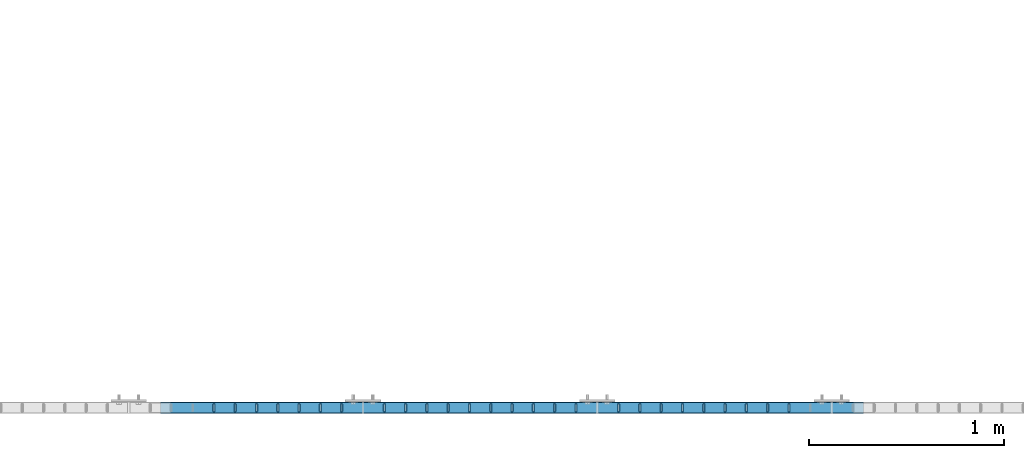
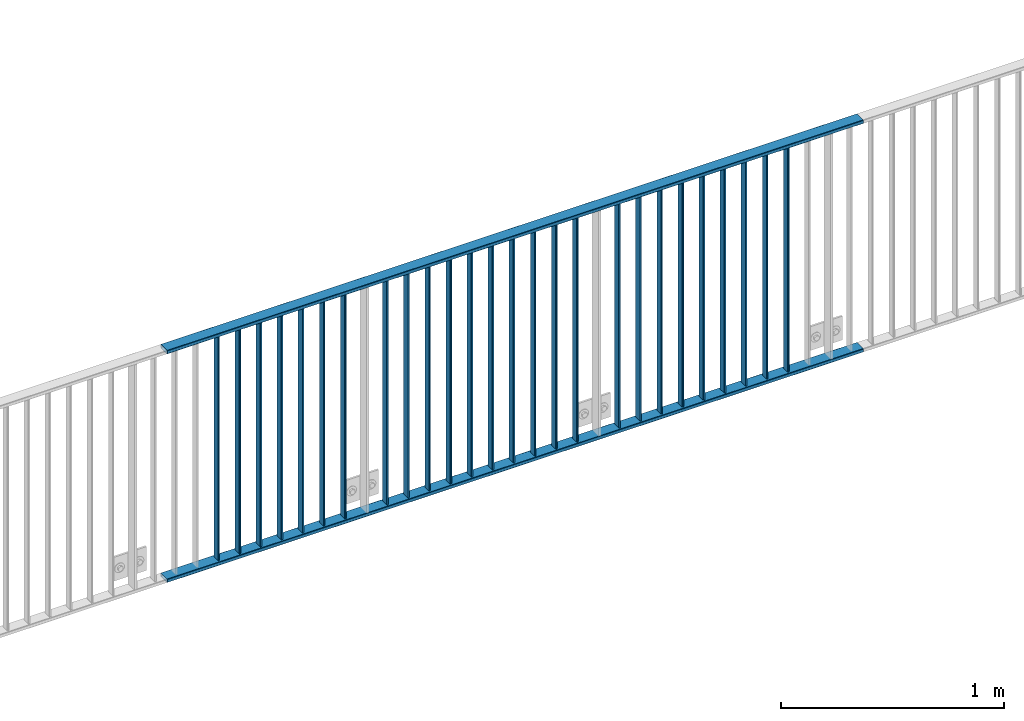
# One storey, part 21 of 156: 28 beams, 1 element without a shape of its own.
"""IFC2X3 building model written with IfcOpenShell, lengths in millimetres."""

from ifc_helpers import new_model, si_unit, frame, origin_with_axes, origin_2d_with_axis, place, context, subcontext, project, spatial, hollow_rectangle, extrude, clip, halfspace, material, type_object, element, aggregate, save


model = new_model("IFC2X3")

# Units and contexts
model_context = context("Model", 3, precision=1e-05, world=origin_with_axes())
body_context = subcontext(model_context, "Body", "Model", "MODEL_VIEW")
ifc_project = project(units=[si_unit("LENGTHUNIT", "METRE", prefix="MILLI"), si_unit("AREAUNIT", "SQUARE_METRE"), si_unit("VOLUMEUNIT", "CUBIC_METRE"), si_unit("MASSUNIT", "GRAM", prefix="KILO"), si_unit("TIMEUNIT", "SECOND"), si_unit("PLANEANGLEUNIT", "RADIAN"), si_unit("SOLIDANGLEUNIT", "STERADIAN"), si_unit("THERMODYNAMICTEMPERATUREUNIT", "DEGREE_CELSIUS"), si_unit("LUMINOUSINTENSITYUNIT", "LUMEN")], contexts=[model_context])

# Site, building, storey
site_placement = place(None, origin_with_axes())
site = spatial("IfcSite", under=ifc_project, at=site_placement, CompositionType="ELEMENT")
building_placement = place(site_placement, origin_with_axes())
building = spatial("IfcBuilding", under=site, at=building_placement, Name="Undefined", CompositionType="ELEMENT")
storey_placement = place(building_placement, origin_with_axes())
storey = spatial("IfcBuildingStorey", under=building, at=storey_placement, Name="Undefined", CompositionType="ELEMENT", Elevation=0.0)

# Assembly, beams
assembly_placement = place(storey_placement, origin_with_axes())
assembly = element("IfcElementAssembly", 1, at=assembly_placement, inside=storey, AssemblyPlace="NOTDEFINED", PredefinedType="RIGID_FRAME")
ifc_material = material(Name="STEEL/S235JR")
beam_type_1 = type_object("IfcBeamType", Name="K60/20/2", PredefinedType="NOTDEFINED")
beam_1_placement = place(assembly_placement, frame((35963.0399999997, 8480.00209045411, 2740.0), z_axis=(0.0, 1.0, 0.0), x_axis=(1.0, 0.0, 0.0)))
beam_1 = element("IfcBeam", 2, at=beam_1_placement, type_object=beam_type_1, material=ifc_material, ObjectType="K60/20/2", context=body_context, shape_type="SweptSolid", body=[
    extrude(hollow_rectangle(XDim=20.0, YDim=60.0, WallThickness=2.0, InnerFilletRadius=2.0, OuterFilletRadius=4.0, at=origin_2d_with_axis()), frame((3600.0, 0.0, 0.0), z_axis=(-1.0, 0.0, 0.0), x_axis=(0.0, -1.0, 0.0)), (0.0, 0.0, 1.0), 3600.0),
])
beam_2_placement = place(assembly_placement, frame((35963.0399999997, 8479.98209035231, 3990.0), z_axis=(0.0, 1.0, 0.0), x_axis=(1.0, 0.0, 0.0)))
beam_2 = element("IfcBeam", 3, at=beam_2_placement, type_object=beam_type_1, material=ifc_material, ObjectType="K60/20/2", context=body_context, shape_type="SweptSolid", body=[
    extrude(hollow_rectangle(XDim=20.0, YDim=60.0, WallThickness=2.0, InnerFilletRadius=2.0, OuterFilletRadius=4.0, at=origin_2d_with_axis()), frame((3600.0, 0.0, 0.0), z_axis=(-1.0, 0.0, 0.0), x_axis=(0.0, -1.0, 0.0)), (0.0, 0.0, 1.0), 3600.0),
])
beam_type_2 = type_object("IfcBeamType", Name="K40/10/1.5", PredefinedType="NOTDEFINED")
beam_3_placement = place(assembly_placement, frame((39181.809999999, 8480.00209765299, 3980.00000000003), z_axis=(0.0, 1.0, 0.0), x_axis=(0.0, 0.0, -1.0)))
beam_3 = element("IfcBeam", 4, at=beam_3_placement, type_object=beam_type_2, material=ifc_material, ObjectType="K40/10/1.5", context=body_context, shape_type="Clipping", body=[
    clip(extrude(hollow_rectangle(XDim=10.0, YDim=40.0, WallThickness=1.5, InnerFilletRadius=1.5, OuterFilletRadius=3.0, at=origin_2d_with_axis()), frame((1230.0, 0.0, 0.0), z_axis=(-1.0, 0.0, 0.0), x_axis=(0.0, -1.0, 0.0)), (0.0, 0.0, 1.0), 1230.0), halfspace(frame((-6.99999999997453, -4.34248751950508, 47.3810900558092), z_axis=(-1.0, 0.0, 0.0), x_axis=(0.0, 0.7683548141934, -0.640024124159258)), False)),
])
beam_4_placement = place(assembly_placement, frame((39072.719999999, 8480.00209765299, 3980.00000000003), z_axis=(0.0, 1.0, 0.0), x_axis=(0.0, 0.0, -1.0)))
beam_4 = element("IfcBeam", 5, at=beam_4_placement, type_object=beam_type_2, material=ifc_material, ObjectType="K40/10/1.5", context=body_context, shape_type="Clipping", body=[
    clip(extrude(hollow_rectangle(XDim=10.0, YDim=40.0, WallThickness=1.5, InnerFilletRadius=1.5, OuterFilletRadius=3.0, at=origin_2d_with_axis()), frame((1230.0, 0.0, 0.0), z_axis=(-1.0, 0.0, 0.0), x_axis=(0.0, -1.0, 0.0)), (0.0, 0.0, 1.0), 1230.0), halfspace(frame((-6.99999999997453, -4.34248751950508, 47.3810900558092), z_axis=(-1.0, 0.0, 0.0), x_axis=(0.0, 0.7683548141934, -0.640024124159258)), False)),
])
beam_5_placement = place(assembly_placement, frame((38963.629999999, 8480.00209765299, 3980.00000000003), z_axis=(0.0, 1.0, 0.0), x_axis=(0.0, 0.0, -1.0)))
beam_5 = element("IfcBeam", 6, at=beam_5_placement, type_object=beam_type_2, material=ifc_material, ObjectType="K40/10/1.5", context=body_context, shape_type="Clipping", body=[
    clip(extrude(hollow_rectangle(XDim=10.0, YDim=40.0, WallThickness=1.5, InnerFilletRadius=1.5, OuterFilletRadius=3.0, at=origin_2d_with_axis()), frame((1230.0, 0.0, 0.0), z_axis=(-1.0, 0.0, 0.0), x_axis=(0.0, -1.0, 0.0)), (0.0, 0.0, 1.0), 1230.0), halfspace(frame((-6.99999999997453, -4.34248751950508, 47.3810900558092), z_axis=(-1.0, 0.0, 0.0), x_axis=(0.0, 0.7683548141934, -0.640024124159258)), False)),
])
beam_6_placement = place(assembly_placement, frame((38854.539999999, 8480.00209765299, 3980.00000000003), z_axis=(0.0, 1.0, 0.0), x_axis=(0.0, 0.0, -1.0)))
beam_6 = element("IfcBeam", 7, at=beam_6_placement, type_object=beam_type_2, material=ifc_material, ObjectType="K40/10/1.5", context=body_context, shape_type="Clipping", body=[
    clip(extrude(hollow_rectangle(XDim=10.0, YDim=40.0, WallThickness=1.5, InnerFilletRadius=1.5, OuterFilletRadius=3.0, at=origin_2d_with_axis()), frame((1230.0, 0.0, 0.0), z_axis=(-1.0, 0.0, 0.0), x_axis=(0.0, -1.0, 0.0)), (0.0, 0.0, 1.0), 1230.0), halfspace(frame((-6.99999999997453, -4.34248751950508, 47.3810900558092), z_axis=(-1.0, 0.0, 0.0), x_axis=(0.0, 0.7683548141934, -0.640024124159258)), False)),
])
beam_7_placement = place(assembly_placement, frame((38745.449999999, 8480.00209765299, 3980.00000000003), z_axis=(0.0, 1.0, 0.0), x_axis=(0.0, 0.0, -1.0)))
beam_7 = element("IfcBeam", 8, at=beam_7_placement, type_object=beam_type_2, material=ifc_material, ObjectType="K40/10/1.5", context=body_context, shape_type="Clipping", body=[
    clip(extrude(hollow_rectangle(XDim=10.0, YDim=40.0, WallThickness=1.5, InnerFilletRadius=1.5, OuterFilletRadius=3.0, at=origin_2d_with_axis()), frame((1230.0, 0.0, 0.0), z_axis=(-1.0, 0.0, 0.0), x_axis=(0.0, -1.0, 0.0)), (0.0, 0.0, 1.0), 1230.0), halfspace(frame((-6.99999999997453, -4.34248751950508, 47.3810900558092), z_axis=(-1.0, 0.0, 0.0), x_axis=(0.0, 0.7683548141934, -0.640024124159258)), False)),
])
beam_8_placement = place(assembly_placement, frame((38636.359999999, 8480.00209765299, 3980.00000000003), z_axis=(0.0, 1.0, 0.0), x_axis=(0.0, 0.0, -1.0)))
beam_8 = element("IfcBeam", 9, at=beam_8_placement, type_object=beam_type_2, material=ifc_material, ObjectType="K40/10/1.5", context=body_context, shape_type="Clipping", body=[
    clip(extrude(hollow_rectangle(XDim=10.0, YDim=40.0, WallThickness=1.5, InnerFilletRadius=1.5, OuterFilletRadius=3.0, at=origin_2d_with_axis()), frame((1230.0, 0.0, 0.0), z_axis=(-1.0, 0.0, 0.0), x_axis=(0.0, -1.0, 0.0)), (0.0, 0.0, 1.0), 1230.0), halfspace(frame((-6.99999999997453, -4.34248751950508, 47.3810900558092), z_axis=(-1.0, 0.0, 0.0), x_axis=(0.0, 0.7683548141934, -0.640024124159258)), False)),
])
beam_9_placement = place(assembly_placement, frame((38527.269999999, 8480.00209765299, 3980.00000000003), z_axis=(0.0, 1.0, 0.0), x_axis=(0.0, 0.0, -1.0)))
beam_9 = element("IfcBeam", 10, at=beam_9_placement, type_object=beam_type_2, material=ifc_material, ObjectType="K40/10/1.5", context=body_context, shape_type="Clipping", body=[
    clip(extrude(hollow_rectangle(XDim=10.0, YDim=40.0, WallThickness=1.5, InnerFilletRadius=1.5, OuterFilletRadius=3.0, at=origin_2d_with_axis()), frame((1230.0, 0.0, 0.0), z_axis=(-1.0, 0.0, 0.0), x_axis=(0.0, -1.0, 0.0)), (0.0, 0.0, 1.0), 1230.0), halfspace(frame((-6.99999999997453, -4.34248751950508, 47.3810900558092), z_axis=(-1.0, 0.0, 0.0), x_axis=(0.0, 0.7683548141934, -0.640024124159258)), False)),
])
beam_10_placement = place(assembly_placement, frame((38418.179999999, 8480.00209765299, 3980.00000000003), z_axis=(0.0, 1.0, 0.0), x_axis=(0.0, 0.0, -1.0)))
beam_10 = element("IfcBeam", 11, at=beam_10_placement, type_object=beam_type_2, material=ifc_material, ObjectType="K40/10/1.5", context=body_context, shape_type="Clipping", body=[
    clip(extrude(hollow_rectangle(XDim=10.0, YDim=40.0, WallThickness=1.5, InnerFilletRadius=1.5, OuterFilletRadius=3.0, at=origin_2d_with_axis()), frame((1230.0, 0.0, 0.0), z_axis=(-1.0, 0.0, 0.0), x_axis=(0.0, -1.0, 0.0)), (0.0, 0.0, 1.0), 1230.0), halfspace(frame((-6.99999999997453, -4.34248751950508, 47.3810900558092), z_axis=(-1.0, 0.0, 0.0), x_axis=(0.0, 0.7683548141934, -0.640024124159258)), False)),
])
beam_11_placement = place(assembly_placement, frame((38309.089999999, 8480.00209765299, 3980.00000000003), z_axis=(0.0, 1.0, 0.0), x_axis=(0.0, 0.0, -1.0)))
beam_11 = element("IfcBeam", 12, at=beam_11_placement, type_object=beam_type_2, material=ifc_material, ObjectType="K40/10/1.5", context=body_context, shape_type="Clipping", body=[
    clip(extrude(hollow_rectangle(XDim=10.0, YDim=40.0, WallThickness=1.5, InnerFilletRadius=1.5, OuterFilletRadius=3.0, at=origin_2d_with_axis()), frame((1230.0, 0.0, 0.0), z_axis=(-1.0, 0.0, 0.0), x_axis=(0.0, -1.0, 0.0)), (0.0, 0.0, 1.0), 1230.0), halfspace(frame((-6.99999999997453, -4.34248751950508, 47.3810900558092), z_axis=(-1.0, 0.0, 0.0), x_axis=(0.0, 0.7683548141934, -0.640024124159258)), False)),
])
beam_12_placement = place(assembly_placement, frame((38090.899999999, 8480.00209765299, 3980.00000000003), z_axis=(0.0, 1.0, 0.0), x_axis=(0.0, 0.0, -1.0)))
beam_12 = element("IfcBeam", 13, at=beam_12_placement, type_object=beam_type_2, material=ifc_material, ObjectType="K40/10/1.5", context=body_context, shape_type="Clipping", body=[
    clip(extrude(hollow_rectangle(XDim=10.0, YDim=40.0, WallThickness=1.5, InnerFilletRadius=1.5, OuterFilletRadius=3.0, at=origin_2d_with_axis()), frame((1230.0, 0.0, 0.0), z_axis=(-1.0, 0.0, 0.0), x_axis=(0.0, -1.0, 0.0)), (0.0, 0.0, 1.0), 1230.0), halfspace(frame((-6.99999999997453, -4.34248751950508, 47.3810900558092), z_axis=(-1.0, 0.0, 0.0), x_axis=(0.0, 0.7683548141934, -0.640024124159258)), False)),
])
beam_13_placement = place(assembly_placement, frame((37981.809999999, 8480.00209765299, 3980.00000000003), z_axis=(0.0, 1.0, 0.0), x_axis=(0.0, 0.0, -1.0)))
beam_13 = element("IfcBeam", 14, at=beam_13_placement, type_object=beam_type_2, material=ifc_material, ObjectType="K40/10/1.5", context=body_context, shape_type="Clipping", body=[
    clip(extrude(hollow_rectangle(XDim=10.0, YDim=40.0, WallThickness=1.5, InnerFilletRadius=1.5, OuterFilletRadius=3.0, at=origin_2d_with_axis()), frame((1230.0, 0.0, 0.0), z_axis=(-1.0, 0.0, 0.0), x_axis=(0.0, -1.0, 0.0)), (0.0, 0.0, 1.0), 1230.0), halfspace(frame((-6.99999999997453, -4.34248751950508, 47.3810900558092), z_axis=(-1.0, 0.0, 0.0), x_axis=(0.0, 0.7683548141934, -0.640024124159258)), False)),
])
beam_14_placement = place(assembly_placement, frame((37872.719999999, 8480.00209765299, 3980.00000000003), z_axis=(0.0, 1.0, 0.0), x_axis=(0.0, 0.0, -1.0)))
beam_14 = element("IfcBeam", 15, at=beam_14_placement, type_object=beam_type_2, material=ifc_material, ObjectType="K40/10/1.5", context=body_context, shape_type="Clipping", body=[
    clip(extrude(hollow_rectangle(XDim=10.0, YDim=40.0, WallThickness=1.5, InnerFilletRadius=1.5, OuterFilletRadius=3.0, at=origin_2d_with_axis()), frame((1230.0, 0.0, 0.0), z_axis=(-1.0, 0.0, 0.0), x_axis=(0.0, -1.0, 0.0)), (0.0, 0.0, 1.0), 1230.0), halfspace(frame((-6.99999999997453, -4.34248751950508, 47.3810900558092), z_axis=(-1.0, 0.0, 0.0), x_axis=(0.0, 0.7683548141934, -0.640024124159258)), False)),
])
beam_15_placement = place(assembly_placement, frame((37763.629999999, 8480.00209765299, 3980.00000000003), z_axis=(0.0, 1.0, 0.0), x_axis=(0.0, 0.0, -1.0)))
beam_15 = element("IfcBeam", 16, at=beam_15_placement, type_object=beam_type_2, material=ifc_material, ObjectType="K40/10/1.5", context=body_context, shape_type="Clipping", body=[
    clip(extrude(hollow_rectangle(XDim=10.0, YDim=40.0, WallThickness=1.5, InnerFilletRadius=1.5, OuterFilletRadius=3.0, at=origin_2d_with_axis()), frame((1230.0, 0.0, 0.0), z_axis=(-1.0, 0.0, 0.0), x_axis=(0.0, -1.0, 0.0)), (0.0, 0.0, 1.0), 1230.0), halfspace(frame((-6.99999999997453, -4.34248751950508, 47.3810900558092), z_axis=(-1.0, 0.0, 0.0), x_axis=(0.0, 0.7683548141934, -0.640024124159258)), False)),
])
beam_16_placement = place(assembly_placement, frame((37654.539999999, 8480.00209765299, 3980.00000000003), z_axis=(0.0, 1.0, 0.0), x_axis=(0.0, 0.0, -1.0)))
beam_16 = element("IfcBeam", 17, at=beam_16_placement, type_object=beam_type_2, material=ifc_material, ObjectType="K40/10/1.5", context=body_context, shape_type="Clipping", body=[
    clip(extrude(hollow_rectangle(XDim=10.0, YDim=40.0, WallThickness=1.5, InnerFilletRadius=1.5, OuterFilletRadius=3.0, at=origin_2d_with_axis()), frame((1230.0, 0.0, 0.0), z_axis=(-1.0, 0.0, 0.0), x_axis=(0.0, -1.0, 0.0)), (0.0, 0.0, 1.0), 1230.0), halfspace(frame((-6.99999999997453, -4.34248751950508, 47.3810900558092), z_axis=(-1.0, 0.0, 0.0), x_axis=(0.0, 0.7683548141934, -0.640024124159258)), False)),
])
beam_17_placement = place(assembly_placement, frame((37545.449999999, 8480.00209765299, 3980.00000000003), z_axis=(0.0, 1.0, 0.0), x_axis=(0.0, 0.0, -1.0)))
beam_17 = element("IfcBeam", 18, at=beam_17_placement, type_object=beam_type_2, material=ifc_material, ObjectType="K40/10/1.5", context=body_context, shape_type="Clipping", body=[
    clip(extrude(hollow_rectangle(XDim=10.0, YDim=40.0, WallThickness=1.5, InnerFilletRadius=1.5, OuterFilletRadius=3.0, at=origin_2d_with_axis()), frame((1230.0, 0.0, 0.0), z_axis=(-1.0, 0.0, 0.0), x_axis=(0.0, -1.0, 0.0)), (0.0, 0.0, 1.0), 1230.0), halfspace(frame((-6.99999999997453, -4.34248751950508, 47.3810900558092), z_axis=(-1.0, 0.0, 0.0), x_axis=(0.0, 0.7683548141934, -0.640024124159258)), False)),
])
beam_18_placement = place(assembly_placement, frame((37436.359999999, 8480.00209765299, 3980.00000000003), z_axis=(0.0, 1.0, 0.0), x_axis=(0.0, 0.0, -1.0)))
beam_18 = element("IfcBeam", 19, at=beam_18_placement, type_object=beam_type_2, material=ifc_material, ObjectType="K40/10/1.5", context=body_context, shape_type="Clipping", body=[
    clip(extrude(hollow_rectangle(XDim=10.0, YDim=40.0, WallThickness=1.5, InnerFilletRadius=1.5, OuterFilletRadius=3.0, at=origin_2d_with_axis()), frame((1230.0, 0.0, 0.0), z_axis=(-1.0, 0.0, 0.0), x_axis=(0.0, -1.0, 0.0)), (0.0, 0.0, 1.0), 1230.0), halfspace(frame((-6.99999999997453, -4.34248751950508, 47.3810900558092), z_axis=(-1.0, 0.0, 0.0), x_axis=(0.0, 0.7683548141934, -0.640024124159258)), False)),
])
beam_19_placement = place(assembly_placement, frame((37327.269999999, 8480.00209765299, 3980.00000000003), z_axis=(0.0, 1.0, 0.0), x_axis=(0.0, 0.0, -1.0)))
beam_19 = element("IfcBeam", 20, at=beam_19_placement, type_object=beam_type_2, material=ifc_material, ObjectType="K40/10/1.5", context=body_context, shape_type="Clipping", body=[
    clip(extrude(hollow_rectangle(XDim=10.0, YDim=40.0, WallThickness=1.5, InnerFilletRadius=1.5, OuterFilletRadius=3.0, at=origin_2d_with_axis()), frame((1230.0, 0.0, 0.0), z_axis=(-1.0, 0.0, 0.0), x_axis=(0.0, -1.0, 0.0)), (0.0, 0.0, 1.0), 1230.0), halfspace(frame((-6.99999999997453, -4.34248751950508, 47.3810900558092), z_axis=(-1.0, 0.0, 0.0), x_axis=(0.0, 0.7683548141934, -0.640024124159258)), False)),
])
beam_20_placement = place(assembly_placement, frame((37218.179999999, 8480.00209765299, 3980.00000000003), z_axis=(0.0, 1.0, 0.0), x_axis=(0.0, 0.0, -1.0)))
beam_20 = element("IfcBeam", 21, at=beam_20_placement, type_object=beam_type_2, material=ifc_material, ObjectType="K40/10/1.5", context=body_context, shape_type="Clipping", body=[
    clip(extrude(hollow_rectangle(XDim=10.0, YDim=40.0, WallThickness=1.5, InnerFilletRadius=1.5, OuterFilletRadius=3.0, at=origin_2d_with_axis()), frame((1230.0, 0.0, 0.0), z_axis=(-1.0, 0.0, 0.0), x_axis=(0.0, -1.0, 0.0)), (0.0, 0.0, 1.0), 1230.0), halfspace(frame((-6.99999999997453, -4.34248751950508, 47.3810900558092), z_axis=(-1.0, 0.0, 0.0), x_axis=(0.0, 0.7683548141934, -0.640024124159258)), False)),
])
beam_21_placement = place(assembly_placement, frame((37109.089999999, 8480.00209765299, 3980.00000000003), z_axis=(0.0, 1.0, 0.0), x_axis=(0.0, 0.0, -1.0)))
beam_21 = element("IfcBeam", 22, at=beam_21_placement, type_object=beam_type_2, material=ifc_material, ObjectType="K40/10/1.5", context=body_context, shape_type="Clipping", body=[
    clip(extrude(hollow_rectangle(XDim=10.0, YDim=40.0, WallThickness=1.5, InnerFilletRadius=1.5, OuterFilletRadius=3.0, at=origin_2d_with_axis()), frame((1230.0, 0.0, 0.0), z_axis=(-1.0, 0.0, 0.0), x_axis=(0.0, -1.0, 0.0)), (0.0, 0.0, 1.0), 1230.0), halfspace(frame((-6.99999999997453, -4.34248751950508, 47.3810900558092), z_axis=(-1.0, 0.0, 0.0), x_axis=(0.0, 0.7683548141934, -0.640024124159258)), False)),
])
beam_22_placement = place(assembly_placement, frame((36890.899999999, 8480.00209765299, 3980.00000000003), z_axis=(0.0, 1.0, 0.0), x_axis=(0.0, 0.0, -1.0)))
beam_22 = element("IfcBeam", 23, at=beam_22_placement, type_object=beam_type_2, material=ifc_material, ObjectType="K40/10/1.5", context=body_context, shape_type="Clipping", body=[
    clip(extrude(hollow_rectangle(XDim=10.0, YDim=40.0, WallThickness=1.5, InnerFilletRadius=1.5, OuterFilletRadius=3.0, at=origin_2d_with_axis()), frame((1230.0, 0.0, 0.0), z_axis=(-1.0, 0.0, 0.0), x_axis=(0.0, -1.0, 0.0)), (0.0, 0.0, 1.0), 1230.0), halfspace(frame((-6.99999999997453, -4.34248751950508, 47.3810900558092), z_axis=(-1.0, 0.0, 0.0), x_axis=(0.0, 0.7683548141934, -0.640024124159258)), False)),
])
beam_23_placement = place(assembly_placement, frame((36781.809999999, 8480.00209765299, 3980.00000000003), z_axis=(0.0, 1.0, 0.0), x_axis=(0.0, 0.0, -1.0)))
beam_23 = element("IfcBeam", 24, at=beam_23_placement, type_object=beam_type_2, material=ifc_material, ObjectType="K40/10/1.5", context=body_context, shape_type="Clipping", body=[
    clip(extrude(hollow_rectangle(XDim=10.0, YDim=40.0, WallThickness=1.5, InnerFilletRadius=1.5, OuterFilletRadius=3.0, at=origin_2d_with_axis()), frame((1230.0, 0.0, 0.0), z_axis=(-1.0, 0.0, 0.0), x_axis=(0.0, -1.0, 0.0)), (0.0, 0.0, 1.0), 1230.0), halfspace(frame((-6.99999999997453, -4.34248751950508, 47.3810900558092), z_axis=(-1.0, 0.0, 0.0), x_axis=(0.0, 0.7683548141934, -0.640024124159258)), False)),
])
beam_24_placement = place(assembly_placement, frame((36672.719999999, 8480.00209765299, 3980.00000000003), z_axis=(0.0, 1.0, 0.0), x_axis=(0.0, 0.0, -1.0)))
beam_24 = element("IfcBeam", 25, at=beam_24_placement, type_object=beam_type_2, material=ifc_material, ObjectType="K40/10/1.5", context=body_context, shape_type="Clipping", body=[
    clip(extrude(hollow_rectangle(XDim=10.0, YDim=40.0, WallThickness=1.5, InnerFilletRadius=1.5, OuterFilletRadius=3.0, at=origin_2d_with_axis()), frame((1230.0, 0.0, 0.0), z_axis=(-1.0, 0.0, 0.0), x_axis=(0.0, -1.0, 0.0)), (0.0, 0.0, 1.0), 1230.0), halfspace(frame((-6.99999999997453, -4.34248751950508, 47.3810900558092), z_axis=(-1.0, 0.0, 0.0), x_axis=(0.0, 0.7683548141934, -0.640024124159258)), False)),
])
beam_25_placement = place(assembly_placement, frame((36563.629999999, 8480.00209765299, 3980.00000000003), z_axis=(0.0, 1.0, 0.0), x_axis=(0.0, 0.0, -1.0)))
beam_25 = element("IfcBeam", 26, at=beam_25_placement, type_object=beam_type_2, material=ifc_material, ObjectType="K40/10/1.5", context=body_context, shape_type="Clipping", body=[
    clip(extrude(hollow_rectangle(XDim=10.0, YDim=40.0, WallThickness=1.5, InnerFilletRadius=1.5, OuterFilletRadius=3.0, at=origin_2d_with_axis()), frame((1230.0, 0.0, 0.0), z_axis=(-1.0, 0.0, 0.0), x_axis=(0.0, -1.0, 0.0)), (0.0, 0.0, 1.0), 1230.0), halfspace(frame((-6.99999999997453, -4.34248751950508, 47.3810900558092), z_axis=(-1.0, 0.0, 0.0), x_axis=(0.0, 0.7683548141934, -0.640024124159258)), False)),
])
beam_26_placement = place(assembly_placement, frame((36454.539999999, 8480.00209765299, 3980.00000000003), z_axis=(0.0, 1.0, 0.0), x_axis=(0.0, 0.0, -1.0)))
beam_26 = element("IfcBeam", 27, at=beam_26_placement, type_object=beam_type_2, material=ifc_material, ObjectType="K40/10/1.5", context=body_context, shape_type="Clipping", body=[
    clip(extrude(hollow_rectangle(XDim=10.0, YDim=40.0, WallThickness=1.5, InnerFilletRadius=1.5, OuterFilletRadius=3.0, at=origin_2d_with_axis()), frame((1230.0, 0.0, 0.0), z_axis=(-1.0, 0.0, 0.0), x_axis=(0.0, -1.0, 0.0)), (0.0, 0.0, 1.0), 1230.0), halfspace(frame((-6.99999999997453, -4.34248751950508, 47.3810900558092), z_axis=(-1.0, 0.0, 0.0), x_axis=(0.0, 0.7683548141934, -0.640024124159258)), False)),
])
beam_27_placement = place(assembly_placement, frame((36345.449999999, 8480.00209765299, 3980.00000000003), z_axis=(0.0, 1.0, 0.0), x_axis=(0.0, 0.0, -1.0)))
beam_27 = element("IfcBeam", 28, at=beam_27_placement, type_object=beam_type_2, material=ifc_material, ObjectType="K40/10/1.5", context=body_context, shape_type="Clipping", body=[
    clip(extrude(hollow_rectangle(XDim=10.0, YDim=40.0, WallThickness=1.5, InnerFilletRadius=1.5, OuterFilletRadius=3.0, at=origin_2d_with_axis()), frame((1230.0, 0.0, 0.0), z_axis=(-1.0, 0.0, 0.0), x_axis=(0.0, -1.0, 0.0)), (0.0, 0.0, 1.0), 1230.0), halfspace(frame((-6.99999999997453, -4.34248751950508, 47.3810900558092), z_axis=(-1.0, 0.0, 0.0), x_axis=(0.0, 0.7683548141934, -0.640024124159258)), False)),
])
beam_28_placement = place(assembly_placement, frame((36236.359999999, 8480.00209765299, 3980.00000000003), z_axis=(0.0, 1.0, 0.0), x_axis=(0.0, 0.0, -1.0)))
beam_28 = element("IfcBeam", 29, at=beam_28_placement, type_object=beam_type_2, material=ifc_material, ObjectType="K40/10/1.5", context=body_context, shape_type="Clipping", body=[
    clip(extrude(hollow_rectangle(XDim=10.0, YDim=40.0, WallThickness=1.5, InnerFilletRadius=1.5, OuterFilletRadius=3.0, at=origin_2d_with_axis()), frame((1230.0, 0.0, 0.0), z_axis=(-1.0, 0.0, 0.0), x_axis=(0.0, -1.0, 0.0)), (0.0, 0.0, 1.0), 1230.0), halfspace(frame((-6.99999999997453, -4.34248751950508, 47.3810900558092), z_axis=(-1.0, 0.0, 0.0), x_axis=(0.0, 0.7683548141934, -0.640024124159258)), False)),
])
aggregate(assembly, [beam_1, beam_2, beam_3, beam_4, beam_5, beam_6, beam_7, beam_8, beam_9, beam_10, beam_11, beam_12, beam_13, beam_14, beam_15, beam_16, beam_17, beam_18, beam_19, beam_20, beam_21, beam_22, beam_23, beam_24, beam_25, beam_26, beam_27, beam_28])

save(model, "model.ifc")
